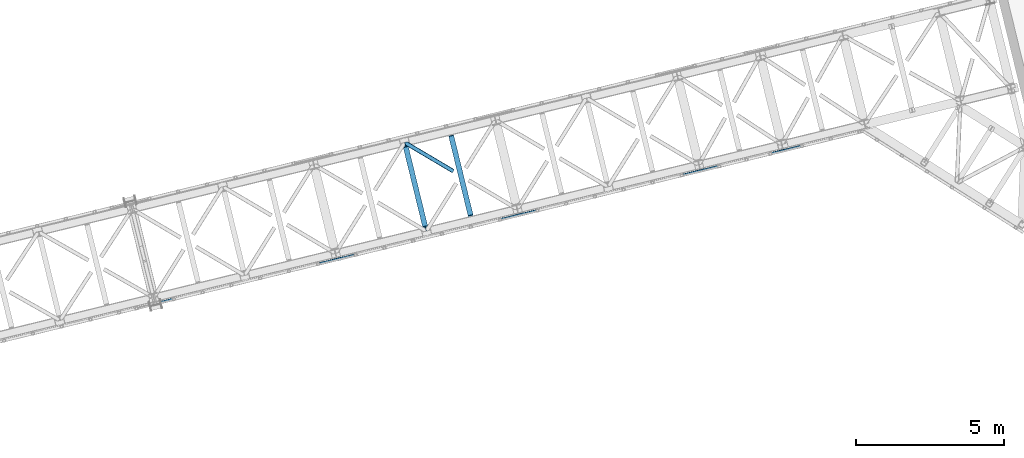
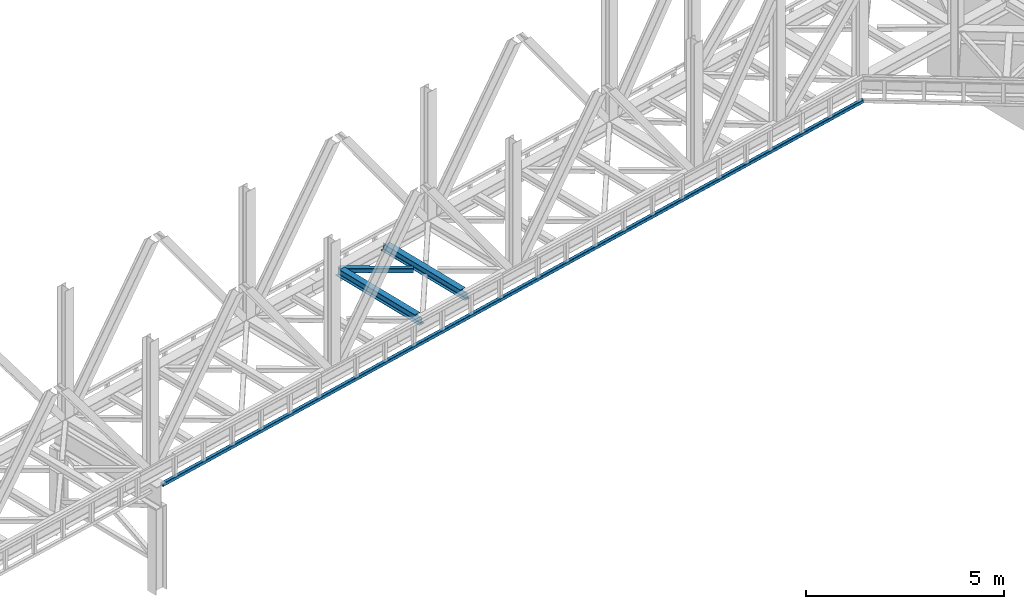
# One storey, part 65 of 93: 3 beams, 1 member.
"""IFC4 building model written with IfcOpenShell, lengths in millimetres."""

from ifc_helpers import new_model, entity, si_unit, converted_unit, derived_unit, direction, frame, origin, place, context, subcontext, project, spatial, triangles, polygons, material, type_object, element, save


model = new_model("IFC4")

# Units and contexts
model_context = context("Model", 3, precision=0.01, world=origin(), true_north=direction((6.12303176911189e-17, 1.0)))
plan_context = context("Plan", 3, precision=0.01, world=origin(), true_north=direction((6.12303176911189e-17, 1.0)))
body_context = subcontext(model_context, "Body", "Model", "MODEL_VIEW")
ifc_project = project(units=[si_unit("LENGTHUNIT", "METRE", prefix="MILLI"), si_unit("AREAUNIT", "SQUARE_METRE"), si_unit("VOLUMEUNIT", "CUBIC_METRE"), converted_unit("PLANEANGLEUNIT", "DEGREE", entity("IfcRatioMeasure", 0.0174532925199433), si_unit("PLANEANGLEUNIT", "RADIAN"), dimensions=[0, 0, 0, 0, 0, 0, 0]), si_unit("MASSUNIT", "GRAM", prefix="KILO"), derived_unit("MASSDENSITYUNIT", [(si_unit("MASSUNIT", "GRAM", prefix="KILO"), 1), (si_unit("LENGTHUNIT", "METRE"), -3)]), derived_unit("MOMENTOFINERTIAUNIT", [(si_unit("LENGTHUNIT", "METRE"), 4)]), si_unit("TIMEUNIT", "SECOND"), si_unit("FREQUENCYUNIT", "HERTZ"), si_unit("THERMODYNAMICTEMPERATUREUNIT", "DEGREE_CELSIUS"), derived_unit("THERMALTRANSMITTANCEUNIT", [(si_unit("MASSUNIT", "GRAM", prefix="KILO"), 1), (si_unit("THERMODYNAMICTEMPERATUREUNIT", "KELVIN"), -1), (si_unit("TIMEUNIT", "SECOND"), -3)]), derived_unit("VOLUMETRICFLOWRATEUNIT", [(si_unit("LENGTHUNIT", "METRE"), 3), (si_unit("TIMEUNIT", "SECOND"), -1)]), derived_unit("MASSFLOWRATEUNIT", [(si_unit("MASSUNIT", "GRAM", prefix="KILO"), 1), (si_unit("TIMEUNIT", "SECOND"), -1)]), derived_unit("ROTATIONALFREQUENCYUNIT", [(si_unit("TIMEUNIT", "SECOND"), -1)]), si_unit("ELECTRICCURRENTUNIT", "AMPERE"), si_unit("ELECTRICVOLTAGEUNIT", "VOLT"), si_unit("POWERUNIT", "WATT"), si_unit("FORCEUNIT", "NEWTON", prefix="KILO"), si_unit("ILLUMINANCEUNIT", "LUX"), si_unit("LUMINOUSFLUXUNIT", "LUMEN"), si_unit("LUMINOUSINTENSITYUNIT", "CANDELA"), derived_unit("USERDEFINED", [(si_unit("MASSUNIT", "GRAM", prefix="KILO"), -1), (si_unit("LENGTHUNIT", "METRE"), -2), (si_unit("TIMEUNIT", "SECOND"), 3), (si_unit("LUMINOUSFLUXUNIT", "LUMEN"), 1)]), derived_unit("LINEARVELOCITYUNIT", [(si_unit("LENGTHUNIT", "METRE"), 1), (si_unit("TIMEUNIT", "SECOND"), -1)]), si_unit("PRESSUREUNIT", "PASCAL"), derived_unit("USERDEFINED", [(si_unit("LENGTHUNIT", "METRE"), -2), (si_unit("MASSUNIT", "GRAM", prefix="KILO"), 1), (si_unit("TIMEUNIT", "SECOND"), -2)]), derived_unit("LINEARFORCEUNIT", [(si_unit("MASSUNIT", "GRAM", prefix="KILO"), 1), (si_unit("LENGTHUNIT", "METRE"), 1), (si_unit("TIMEUNIT", "SECOND"), -2), (si_unit("LENGTHUNIT", "METRE"), -1)]), derived_unit("PLANARFORCEUNIT", [(si_unit("MASSUNIT", "GRAM", prefix="KILO"), 1), (si_unit("LENGTHUNIT", "METRE"), 1), (si_unit("TIMEUNIT", "SECOND"), -2), (si_unit("LENGTHUNIT", "METRE"), -2)])], contexts=[model_context, plan_context])

# Site, building, storey
site_placement = place(None, origin())
site = spatial("IfcSite", under=ifc_project, at=site_placement, CompositionType="ELEMENT")
building_placement = place(site_placement, origin())
building = spatial("IfcBuilding", under=site, at=building_placement, CompositionType="ELEMENT")
storey_placement = place(building_placement, frame((0.0, 0.0, 15900.0)))
storey = spatial("IfcBuildingStorey", under=building, at=storey_placement, CompositionType="ELEMENT", Elevation=15900.0)

# Beams
ifc_material = material(Name="Metal painted (White)")
beam_type_1 = type_object("IfcBeamType", PredefinedType="BEAM")
beam_1_placement = place(storey_placement, frame((-21033.994134998, 12667.6706069707, 3441.0)))
element("IfcBeam", 1, at=beam_1_placement, inside=storey, type_object=beam_type_1, material=ifc_material, ObjectType="Steel Beam", PredefinedType="BEAM", context=body_context, shape_type="Tessellation", body=[
    polygons([(896.722476515612, 41.4445662733146, 11.000000000004), (896.722476515612, 41.4445662733146, 2.16573425859679e-12), (170.021610174765, 3022.65205668043, 2.16573425859679e-12), (170.021610174765, 3022.65205668043, 11.000000000004), (830.65693656199, 25.3403919499699, 11.000000000004), (103.956070221139, 3006.54788235708, 11.000000000004), (824.708186540694, 23.8903211957439, 12.2179274798217), (98.007320199847, 3005.09781160286, 12.2179274798217), (819.665079784585, 22.6610105689237, 15.6862915010257), (92.964213443734, 3003.86850097604, 15.6862915010257), (816.295383581409, 21.8396114687162, 20.8770650821657), (89.5945172405581, 3003.04710187583, 20.8770650821657), (815.112103631732, 21.5511744621271, 27.0000000000047), (88.4112372908809, 3002.75866486924, 27.0000000000047), (81.6103728838844, 3001.1008822183, 27.0000000000047), (81.6103728838888, 3001.1008822183, 203.000000000006), (88.4112372908939, 3002.75866486924, 203.000000000006), (0.0, 2981.20749040711, 2.16573425859679e-12), (4.33146851719357e-12, 2981.20749040712, 10.9999999999997), (66.0655399536302, 2997.31166473046, 11.000000000004), (72.0142899749184, 2998.76173548469, 12.2179274798195), (77.0573967310313, 2999.99104611151, 15.6862915010192), (80.4270929342072, 3000.81244521171, 20.8770650821657), (815.11210363174, 21.5511744621271, 203.000000000006), (808.311239224731, 19.8933918111941, 203.000000000006), (808.311239224731, 19.8933918111919, 27.0000000000047), (807.127959275054, 19.6049548046028, 20.8770650821657), (803.758263071878, 18.7835557043952, 15.6862915010192), (798.715156315769, 17.5542450775729, 12.2179274798195), (792.766406294477, 16.1041743233468, 11.000000000004), (726.700866340851, 2.16573425859679e-12, 10.9999999999997), (726.700866340847, 2.16573425859679e-12, 2.16573425859679e-12), (775.945201911975, 182.229070489536, 203.069792164282), (124.290390378924, 2855.56852806081, 203.000000000006), (124.513271168078, 2854.65418562638, 203.617301946336), (124.526185412598, 2854.60120565349, 217.000003693143), (775.799998669244, 182.824605273263, 217.000003676718), (775.800869277142, 182.821033832383, 204.00000679514), (769.234900758903, 180.199471824636, 203.006342981088), (769.012053092176, 181.113823838963, 203.617301946336), (768.999138847657, 181.166803811856, 217.000003693143), (117.725325591011, 2852.94340419209, 217.000003676718), (117.724454983117, 2852.94697563296, 204.00000679514), (117.580155394058, 2853.53894853354, 203.076120467494), (117.489525971923, 2853.91074540987, 203.000000000006), (776.983483393267, 183.112202246701, 223.122939328039), (780.352479801942, 183.936472070578, 228.313710402595), (785.395115205966, 185.167716295886, 231.782072735464), (791.343694076674, 186.618489150568, 232.999999602236), (857.409144942201, 202.723028934504, 232.999999283132), (857.407671605764, 202.729072911377, 243.999994005812), (687.386290701834, 161.283566114484, 243.999994827032), (687.387764038276, 161.277522137611, 233.000000104353), (753.453214903804, 177.382061921547, 232.999999785253), (759.402120032129, 178.83149638977, 231.782072861016), (764.445684539269, 180.058929212905, 228.313710479427), (767.816071449005, 180.877494870334, 223.12293937232), (116.541840866984, 2852.65580721864, 223.122939328039), (113.172844458304, 2851.83153739476, 228.313710402595), (108.130209054276, 2850.60029316945, 231.782072735464), (102.181630183577, 2849.14952031477, 232.999999602236), (36.1161793180448, 2833.04498053084, 232.999999283128), (36.1176526544823, 2833.03893655396, 243.999994005812), (206.139033558408, 2874.48444335086, 243.999994827032), (206.13756022197, 2874.49048732773, 233.000000104357), (140.072109356447, 2858.38594754379, 232.999999785253), (134.123204228112, 2856.93651307557, 231.782072861012), (129.079639720982, 2855.70908025244, 228.313710479427), (125.709252811241, 2854.89051459501, 223.12293937232)], [[[1, 2, 3, 4]], [[5, 1, 4, 6]], [[7, 5, 6, 8]], [[9, 7, 8, 10]], [[11, 9, 10, 12]], [[13, 11, 12, 14]], [[15, 16, 17, 14, 12, 10, 8, 6, 4, 3, 18, 19, 20, 21, 22, 23]], [[13, 24, 25, 26, 27, 28, 29, 30, 31, 32, 2, 1, 5, 7, 9, 11]], [[2, 32, 18, 3]], [[32, 31, 19, 18]], [[31, 30, 20, 19]], [[27, 26, 15, 23]], [[28, 27, 23, 22]], [[29, 28, 22, 21]], [[30, 29, 21, 20]], [[33, 24, 13, 14, 17, 34, 35, 36, 37, 38]], [[25, 39, 40, 41, 42, 43, 44, 16, 15, 26]], [[39, 25, 24, 33]], [[45, 34, 17, 16]], [[41, 40, 38, 37, 46, 47, 48, 49, 50, 51, 52, 53, 54, 55, 56, 57]], [[42, 58, 59, 60, 61, 62, 63, 64, 65, 66, 67, 68, 69, 36, 35, 43]], [[46, 37, 36, 69]], [[47, 46, 69, 68]], [[48, 47, 68, 67]], [[49, 48, 67, 66]], [[50, 49, 66, 65]], [[51, 50, 65, 64]], [[52, 51, 64, 63]], [[53, 52, 63, 62]], [[54, 53, 62, 61]], [[55, 54, 61, 60]], [[56, 55, 60, 59]], [[57, 56, 59, 58]], [[41, 57, 58, 42]]], closed=False),
])
beam_2_placement = place(storey_placement, frame((-19498.9418831345, 13041.8558338955, 3441.0)))
element("IfcBeam", 2, at=beam_2_placement, inside=storey, type_object=beam_type_1, material=ifc_material, ObjectType="Steel Beam", PredefinedType="BEAM", context=body_context, shape_type="Tessellation", body=[
    polygons([(896.722476515612, 41.4445662733125, 11.000000000004), (896.722476515612, 41.4445662733125, 2.16573425859679e-12), (170.021610174761, 3022.65205668042, 2.16573425859679e-12), (170.021610174763, 3022.65205668042, 11.000000000004), (830.656936561993, 25.3403919499656, 11.000000000004), (103.956070221144, 3006.54788235708, 11.000000000004), (824.708186540689, 23.8903211957374, 12.217927479826), (98.0073201998383, 3005.09781160285, 12.217927479826), (819.665079784589, 22.6610105689237, 15.6862915010192), (92.9642134437362, 3003.86850097603, 15.6862915010192), (816.295383581413, 21.8396114687119, 20.8770650821657), (89.5945172405603, 3003.04710187582, 20.8770650821657), (815.11210363173, 21.5511744621227, 27.0000000000047), (88.4112372908809, 3002.75866486924, 27.0000000000047), (81.6103728838822, 3001.1008822183, 27.0000000000047), (81.6103728838801, 3001.1008822183, 203.000000000006), (88.4112372908809, 3002.75866486924, 203.000000000006), (0.0, 2981.20749040711, 2.16573425859679e-12), (2.16573425859679e-12, 2981.20749040711, 10.9999999999997), (66.0655399536216, 2997.31166473045, 11.000000000004), (72.0142899749205, 2998.76173548469, 12.2179274798217), (77.0573967310183, 2999.9910461115, 15.686291501017), (80.4270929342029, 3000.81244521171, 20.8770650821657), (815.112103631732, 21.5511744621249, 203.000000000006), (808.311239224731, 19.8933918111897, 203.000000000006), (808.311239224731, 19.8933918111897, 27.0000000000047), (807.127959275052, 19.6049548045984, 20.8770650821657), (803.758263071869, 18.7835557043909, 15.686291501017), (798.715156315769, 17.5542450775729, 12.2179274798217), (792.766406294472, 16.1041743233447, 11.000000000004), (726.700866340851, 2.16573425859679e-12, 10.9999999999997), (726.700866340851, 2.16573425859679e-12, 2.16573425859679e-12), (775.945201911964, 182.229070489534, 203.069792164282), (124.290390378922, 2855.5685280608, 203.000000000006), (124.513271168068, 2854.65418562638, 203.617301946336), (124.526185412589, 2854.60120565348, 217.000003693143), (775.79999866924, 182.824605273258, 217.000003676718), (775.800869277134, 182.821033832379, 204.00000679514), (769.234900758899, 180.199471824632, 203.006342981088), (769.012053092174, 181.113823838958, 203.617301946336), (768.999138847649, 181.166803811849, 217.000003693143), (117.725325591002, 2852.94340419208, 217.000003676718), (117.724454983108, 2852.94697563296, 204.00000679514), (117.580155394052, 2853.53894853353, 203.076120467494), (117.489525971919, 2853.91074540987, 203.000000000006), (776.983483393269, 183.112202246699, 223.122939328039), (780.352479801942, 183.93647207058, 228.313710402595), (785.395115205957, 185.167716295882, 231.78207273546), (791.343694076674, 186.618489150565, 232.999999602236), (857.40914494219, 202.723028934499, 232.999999283132), (857.407671605755, 202.729072911373, 243.999994005812), (687.38629070184, 161.283566114482, 243.999994827032), (687.38776403828, 161.277522137609, 233.000000104353), (753.453214903799, 177.382061921543, 232.999999785253), (759.402120032134, 178.831496389768, 231.782072861012), (764.445684539254, 180.058929212901, 228.313710479431), (767.816071449001, 180.877494870332, 223.12293937232), (116.541840866979, 2852.65580721863, 223.122939328039), (113.172844458293, 2851.83153739476, 228.313710402599), (108.130209054278, 2850.60029316945, 231.782072735464), (102.181630183568, 2849.14952031477, 232.999999602236), (36.1161793180448, 2833.04498053084, 232.999999283128), (36.1176526544823, 2833.03893655396, 243.999994005812), (206.139033558399, 2874.48444335085, 243.999994827032), (206.137560221957, 2874.49048732772, 233.000000104357), (140.072109356447, 2858.38594754379, 232.999999785253), (134.123204228102, 2856.93651307557, 231.782072861007), (129.079639720982, 2855.70908025243, 228.313710479427), (125.709252811245, 2854.89051459501, 223.12293937232)], [[[1, 2, 3, 4]], [[5, 1, 4, 6]], [[7, 5, 6, 8]], [[9, 7, 8, 10]], [[11, 9, 10, 12]], [[13, 11, 12, 14]], [[15, 16, 17, 14, 12, 10, 8, 6, 4, 3, 18, 19, 20, 21, 22, 23]], [[13, 24, 25, 26, 27, 28, 29, 30, 31, 32, 2, 1, 5, 7, 9, 11]], [[2, 32, 18, 3]], [[32, 31, 19, 18]], [[31, 30, 20, 19]], [[27, 26, 15, 23]], [[28, 27, 23, 22]], [[29, 28, 22, 21]], [[30, 29, 21, 20]], [[33, 24, 13, 14, 17, 34, 35, 36, 37, 38]], [[25, 39, 40, 41, 42, 43, 44, 16, 15, 26]], [[39, 25, 24, 33]], [[45, 34, 17, 16]], [[41, 40, 38, 37, 46, 47, 48, 49, 50, 51, 52, 53, 54, 55, 56, 57]], [[42, 58, 59, 60, 61, 62, 63, 64, 65, 66, 67, 68, 69, 36, 35, 43]], [[46, 37, 36, 69]], [[47, 46, 69, 68]], [[48, 47, 68, 67]], [[49, 48, 67, 66]], [[50, 49, 66, 65]], [[51, 50, 65, 64]], [[52, 51, 64, 63]], [[53, 52, 63, 62]], [[54, 53, 62, 61]], [[55, 54, 61, 60]], [[56, 55, 60, 59]], [[57, 56, 59, 58]], [[41, 57, 58, 42]]], closed=False),
])

# Member
member_type = type_object("IfcMemberType", PredefinedType="BRACE")
member_placement = place(storey_placement, frame((-20945.2866394043, 14645.7781311035, 3510.00011901855)))
element("IfcMember", 3, at=member_placement, inside=storey, type_object=member_type, ObjectType="Steel Horizontal Brace", PredefinedType="BRACE", context=body_context, shape_type="Tessellation", body=[
    triangles([(1672.21653442383, 120.471716308593, 122.500662231447), (1672.21653442383, 120.471716308593, 17.5000946044929), (91.5013916015632, 1056.29133911133, 122.500662231447), (91.5013916015632, 1056.29133911133, 17.5000946044929), (1663.30196228027, 105.413333129884, 139.999594116212), (1666.71221923828, 111.175772094726, 138.667117309571), (76.4813781738267, 1052.62993469238, 138.667117309571), (67.167993164061, 1050.36030578613, 139.999594116212), (1669.60506591797, 116.060357666016, 134.874325561526), (84.376245117186, 1054.55423583984, 134.874325561526), (1671.53750610352, 119.325274658204, 129.197927856447), (89.6480163574233, 1055.84020385742, 129.197927856447), (18.7686218261733, 956.992749023439, 139.999594116212), (1609.80987854004, 15.0595458984371, 139.999594116212), (0.0, 1033.98688659668, 139.999594116212), (1600.89065551758, 0.0, 122.500662231447), (1601.57317199707, 1.14760437011682, 129.197927856447), (24.5612915039055, 933.226757812501, 122.500662231447), (24.1217834472664, 935.035949707031, 129.197927856447), (1603.50677490234, 4.41135864257922, 134.874325561526), (22.8660461425789, 940.18796081543, 134.874325561526), (1606.39962158203, 9.29710693359448, 138.667117309571), (20.9847656249985, 947.897955322265, 138.667117309571), (1600.89065551758, 0.0, 17.5000946044929), (24.5612915039055, 933.226757812501, 17.5000946044929), (1671.53750610352, 119.325274658204, 10.8028289794929), (89.5619750976548, 1055.81927490234, 10.8167816162131), (162.736578369142, 1012.4207611084, 10.5005218505867), (1669.60506591797, 116.060357666016, 5.12526855468968), (165.152709960938, 1006.73157348633, 5.12526855468968), (164.09696044922, 1011.0638671875, 9.50058288574292), (163.769073486328, 1011.39059143067, 9.74126586914281), (163.420257568359, 1011.74289550781, 10.0005523681648), (163.066790771485, 1012.09287414551, 10.2586761474631), (89.473608398439, 1055.79718322754, 10.5005218505867), (1666.71221923828, 111.175772094726, 1.33247680664135), (167.033990478514, 999.020416259766, 1.33247680664135), (1663.30196228027, 105.413333129884, 0.0), (169.250134277343, 989.925622558594, 0.0), (1609.80987854004, 15.0595458984371, 0.0), (204.010803222656, 847.325024414064, 0.0), (166.88748779297, 995.391567993165, 10.5005218505867), (72.0351379394524, 1051.54627990723, 10.5005218505867), (168.582733154297, 992.660339355469, 9.50058288574292), (168.166479492189, 993.33355407715, 9.74591674804833), (167.738598632812, 994.02653503418, 10.0005523681648), (167.306066894533, 994.718353271484, 10.2540252685576), (1666.03784179688, 110.037469482422, 12.1260040283232), (1667.97028198242, 113.301223754883, 17.8035644531265), (79.9160522460952, 1053.46709289551, 17.8035644531265), (1663.14499511719, 105.151721191407, 8.3320495605476), (169.398962402345, 989.317520141602, 8.81690368652562), (74.1140808105483, 1052.05322570801, 12.4271484375022), (171.566271972657, 980.419226074218, 6.99957275390625), (1659.73357543945, 99.3892822265625, 6.99957275390625), (1668.64814758301, 114.447665405274, 24.4996673583992), (81.7694274902351, 1053.91822814941, 24.4996673583992), (1668.64814758301, 114.447665405274, 115.501089477541), (81.7694274902351, 1053.91822814941, 115.501089477541), (74.641955566407, 1052.18228759766, 127.87475280762), (66.7494140624985, 1050.25798645019, 131.667544555665), (79.9160522460952, 1053.46709289551, 122.196029663086), (57.4360290527329, 1047.98719482422, 133.000021362306), (0.0, 1033.98688659668, 133.000021362306), (1667.97028198242, 113.301223754883, 122.196029663086), (1666.03784179688, 110.037469482422, 127.87475280762), (1663.14499511719, 105.151721191407, 131.667544555665), (1659.73357543945, 99.3892822265625, 133.000021362306), (16.4501586914048, 966.50030822754, 133.000021362306), (1613.37361450195, 21.0824340820309, 133.000021362306), (1613.37361450195, 21.0824340820309, 6.99957275390625), (201.692340087891, 856.832583618165, 6.99957275390625), (1607.06934814453, 10.434246826173, 127.87475280762), (1609.96219482422, 15.3199951171882, 131.667544555665), (1604.4590423584, 6.02405090332104, 115.501089477541), (1605.13690795899, 7.17049255371057, 122.196029663086), (1606.39962158203, 9.29710693359448, 1.33247680664135), (1607.06934814453, 10.434246826173, 12.1260040283232), (1603.50677490234, 4.41135864257922, 5.12526855468968), (1609.96219482422, 15.3199951171882, 8.3320495605476), (1601.57317199707, 1.14760437011682, 10.8028289794929), (1604.4590423584, 6.02405090332104, 24.4996673583992), (1605.13690795899, 7.17049255371057, 17.8035644531265), (18.6686279296882, 957.404351806641, 131.667544555665), (20.547583007814, 949.694357299804, 127.87475280762), (21.8033203125015, 944.542346191407, 122.196029663086), (22.2451538085952, 942.733154296875, 115.501089477541), (22.2451538085952, 942.733154296875, 24.4996673583992), (21.7823913574211, 944.627224731446, 17.8163543701194), (21.7614624023445, 944.717916870117, 17.5000946044929), (203.861975097658, 847.933126831054, 8.81690368652562), (206.226947021485, 838.23023071289, 1.33247680664135), (204.678204345702, 844.590307617187, 9.50058288574292), (208.105902099611, 830.520236206055, 5.12526855468968), (209.163977050783, 826.187942504883, 9.50058288574292), (204.682855224608, 843.327593994141, 10.2075164794951), (204.324737548828, 843.305502319336, 10.3540191650391), (203.966619873048, 843.284573364259, 10.5005218505867), (27.0146301269524, 945.867846679688, 12.1260040283232), (28.3471069335938, 947.254971313478, 10.5005218505867), (204.682855224608, 843.958950805665, 9.85404968261719), (32.1398986816421, 930.362979125977, 10.8179443359404), (209.136071777342, 825.983303833009, 9.88311767578125), (208.117529296876, 826.255380249024, 10.5005218505867), (208.803533935548, 826.071670532227, 10.0842681884787), (32.4980163574219, 930.225778198243, 10.5005218505867)], [[1, 2, 3], [4, 3, 2], [5, 6, 7], [7, 8, 5], [6, 9, 10], [10, 7, 6], [9, 11, 12], [12, 10, 9], [11, 1, 3], [3, 12, 11], [5, 13, 14], [13, 5, 8], [15, 13, 8], [16, 17, 18], [19, 18, 17], [17, 20, 19], [21, 19, 20], [20, 22, 21], [23, 21, 22], [22, 14, 23], [13, 23, 14], [24, 16, 18], [18, 25, 24], [26, 27, 4], [27, 26, 28], [26, 29, 30], [30, 31, 26], [26, 32, 33], [32, 26, 31], [26, 34, 28], [34, 26, 33], [28, 35, 27], [29, 36, 37], [37, 30, 29], [36, 38, 39], [39, 37, 36], [4, 2, 26], [38, 40, 41], [41, 39, 38], [28, 42, 35], [43, 35, 42], [31, 44, 45], [45, 32, 31], [32, 45, 46], [46, 33, 32], [33, 46, 47], [47, 34, 33], [34, 47, 42], [42, 28, 34], [48, 49, 50], [45, 51, 46], [45, 44, 51], [42, 47, 51], [47, 46, 51], [44, 52, 51], [48, 53, 42], [42, 51, 48], [53, 43, 42], [51, 52, 54], [54, 55, 51], [50, 53, 48], [49, 56, 57], [57, 50, 49], [56, 58, 59], [59, 57, 56], [60, 61, 7], [10, 60, 7], [10, 12, 62], [60, 10, 62], [62, 12, 3], [61, 8, 7], [15, 63, 64], [15, 8, 63], [61, 63, 8], [62, 3, 59], [57, 4, 50], [3, 57, 59], [4, 27, 50], [3, 4, 57], [35, 50, 27], [35, 53, 50], [35, 43, 53], [58, 65, 59], [62, 59, 65], [65, 66, 62], [60, 62, 66], [66, 67, 60], [61, 60, 67], [67, 68, 61], [63, 61, 68], [68, 69, 63], [68, 70, 69], [69, 64, 63], [71, 55, 72], [54, 72, 55], [11, 66, 65], [58, 2, 1], [11, 65, 1], [11, 9, 66], [65, 58, 1], [66, 9, 6], [68, 5, 14], [5, 67, 6], [67, 5, 68], [67, 66, 6], [26, 48, 29], [56, 2, 58], [2, 49, 26], [49, 2, 56], [26, 49, 48], [38, 55, 40], [36, 29, 48], [48, 51, 36], [51, 55, 38], [38, 36, 51], [73, 22, 20], [14, 70, 68], [14, 74, 70], [74, 14, 22], [73, 74, 22], [75, 16, 24], [17, 76, 73], [20, 17, 73], [76, 17, 16], [75, 76, 16], [77, 78, 79], [40, 55, 71], [71, 80, 40], [80, 78, 77], [77, 40, 80], [81, 79, 78], [24, 82, 75], [83, 24, 81], [24, 83, 82], [83, 81, 78], [70, 74, 84], [84, 69, 70], [74, 73, 85], [85, 84, 74], [73, 76, 86], [86, 85, 73], [76, 75, 87], [87, 86, 76], [75, 82, 87], [88, 87, 82], [86, 87, 18], [18, 19, 86], [21, 86, 19], [86, 21, 85], [18, 88, 25], [89, 90, 25], [25, 88, 89], [87, 88, 18], [84, 23, 13], [15, 69, 13], [64, 69, 15], [84, 85, 23], [23, 85, 21], [69, 84, 13], [44, 30, 37], [39, 44, 37], [54, 52, 39], [54, 39, 72], [30, 44, 31], [39, 52, 44], [72, 41, 91], [41, 92, 93], [41, 72, 39], [94, 93, 92], [41, 93, 91], [94, 95, 93], [83, 89, 88], [71, 72, 91], [78, 96, 97], [97, 98, 78], [98, 99, 78], [98, 100, 99], [80, 91, 93], [93, 78, 80], [78, 93, 101], [101, 96, 78], [83, 78, 99], [99, 90, 83], [90, 89, 83], [91, 80, 71], [88, 82, 83], [24, 25, 102], [79, 103, 95], [81, 102, 104], [104, 79, 81], [104, 105, 79], [95, 94, 79], [40, 77, 92], [92, 41, 40], [77, 79, 94], [94, 92, 77], [106, 81, 24], [99, 106, 25], [99, 100, 106], [25, 90, 99], [98, 104, 106], [106, 100, 98]]),
])

# Beam
beam_type_2 = type_object("IfcBeamType", PredefinedType="BEAM")
beam_3_placement = place(storey_placement, frame((-29196.8992492676, 10223.7131652832, 3068.00035400391)))
element("IfcBeam", 4, at=beam_3_placement, inside=storey, type_object=beam_type_2, ObjectType="Steel Beam", PredefinedType="BEAM", context=body_context, shape_type="Tessellation", body=[
    triangles([(23740.1770889282, 5873.7821685791, 0.0), (23726.1331787109, 5788.01531066895, 0.0), (2.36729736328198, 87.4400115966801, 0.0), (21.3149780273452, 9.71568603515698, 0.0), (0.0, 97.1545349121097, 9.9993896484375), (23741.9339584351, 5884.50244445801, 9.9993896484375), (23741.6758346558, 5882.93277282715, 6.4647216796875), (0.181384277344478, 96.4150451660153, 6.17287902831958), (23741.4211990356, 5881.36310119629, 2.92889099121021), (0.692980957031978, 94.3093597412117, 2.92889099121021), (23740.7991439819, 5877.5726348877, 1.46386413574146), (1.46270141601417, 91.1572265625, 0.760418701171147), (0.0, 97.1545349121097, 90.0003204345703), (23741.9339584351, 5884.50244445801, 90.0003204345703), (1.46270141601417, 91.1572265625, 99.2381286621094), (2.36729736328198, 87.4400115966801, 99.9997100830078), (23740.1770889282, 5873.7821685791, 99.9997100830078), (0.692980957031978, 94.3093597412117, 97.0708190917976), (23740.7991439819, 5877.5726348877, 98.5358459472664), (0.181384277344478, 96.4150451660153, 93.8268310546882), (23741.4211990356, 5881.36310119629, 97.0708190917976), (23741.6758346558, 5882.93277282715, 93.5349884033203), (23726.1331787109, 5788.01531066895, 99.9997100830078), (21.3149780273452, 9.71568603515698, 99.9997100830078), (23.5032165527336, 0.739489746094478, 93.8268310546882), (23.6822753906235, 0.0, 90.0003204345703), (23724.3757278442, 5777.29503479004, 90.0003204345703), (22.9892944335952, 2.84517517089807, 97.0708190917976), (23724.6344329834, 5778.8647064209, 93.5349884033203), (22.2195739746094, 5.99730834960974, 99.2381286621094), (23724.8931381226, 5780.43554077148, 97.0708190917976), (23725.5111236572, 5784.22484436035, 98.5358459472664), (23.6822753906235, 0.0, 9.9993896484375), (23724.3757278442, 5777.29503479004, 9.9993896484375), (23725.5111236572, 5784.22484436035, 1.46386413574146), (22.2195739746094, 5.99730834960974, 0.760418701171147), (23724.8931381226, 5780.43554077148, 2.92889099121021), (22.9892944335952, 2.84517517089807, 2.92889099121021), (23724.6344329834, 5778.8647064209, 6.4647216796875), (23.5032165527336, 0.739489746094478, 6.17287902831958), (1.87662963867115, 89.4515167236332, 7.92858581542896), (1.36503295898365, 91.5583648681641, 11.1725738525383), (1.18364868163917, 92.2978546142585, 15.0002471923835), (3.55327148437573, 82.5821685791016, 4.99969482421875), (2.64635009765698, 86.2993835449215, 5.76127624511719), (1.87662963867115, 89.4515167236332, 92.0711242675789), (1.18364868163917, 92.2978546142585, 84.9994628906243), (1.36503295898365, 91.5583648681641, 88.8271362304695), (3.55327148437573, 82.5821685791016, 95.0000152587891), (2.64635009765698, 86.2993835449215, 94.2384338378906), (21.8056457519524, 7.70301818847656, 7.92858581542896), (20.1313293457024, 14.5735290527355, 4.99969482421875), (21.0359252929702, 10.8551513671882, 5.76127624511719), (22.4986267089844, 4.85784301757849, 15.0002471923835), (22.3172424316399, 5.59733276367297, 11.1725738525383), (21.8056457519524, 7.70301818847656, 92.0711242675789), (20.1313293457024, 14.5735290527355, 95.0000152587891), (21.0359252929702, 10.8551513671882, 94.2384338378906), (22.4986267089844, 4.85784301757849, 84.9994628906243), (22.3172424316399, 5.59733276367297, 88.8271362304695), (23740.5404388428, 5876.00180053711, 7.92858581542896), (23739.923034668, 5872.21249694824, 6.4647216796875), (23740.5404388428, 5876.00180053711, 92.0711242675789), (23740.7991439819, 5877.5726348877, 88.5352935791016), (23741.0578491211, 5879.14230651856, 84.9994628906243), (23741.0578491211, 5879.14230651856, 15.0002471923835), (23739.3009796143, 5868.42203063965, 95.0000152587891), (23727.0092880249, 5793.3754486084, 95.0000152587891), (23739.923034668, 5872.21249694824, 93.5349884033203), (23740.7991439819, 5877.5726348877, 11.4644165039063), (23739.3009796143, 5868.42203063965, 4.99969482421875), (23725.7692474365, 5785.79567871094, 92.0711242675789), (23725.5111236572, 5784.22484436035, 88.5352935791016), (23726.3918838501, 5789.58614501953, 93.5349884033203), (23725.2564880371, 5782.65517272949, 84.9994628906243), (23725.7692474365, 5785.79567871094, 7.92858581542896), (23727.0092880249, 5793.3754486084, 4.99969482421875), (23726.3918838501, 5789.58614501953, 6.4647216796875), (23725.2564880371, 5782.65517272949, 15.0002471923835), (23725.5111236572, 5784.22484436035, 11.4644165039063)], [[1, 2, 3], [4, 3, 2], [5, 6, 7], [8, 7, 9], [10, 9, 11], [12, 11, 1], [1, 3, 12], [11, 12, 10], [9, 10, 8], [7, 8, 5], [6, 5, 13], [13, 14, 6], [15, 16, 17], [18, 15, 19], [20, 18, 21], [13, 20, 22], [22, 14, 13], [21, 22, 20], [19, 21, 18], [17, 19, 15], [23, 17, 16], [16, 24, 23], [25, 26, 27], [28, 25, 29], [30, 28, 31], [24, 30, 32], [32, 23, 24], [31, 32, 30], [29, 31, 28], [27, 29, 25], [33, 34, 27], [27, 26, 33], [4, 2, 35], [36, 35, 37], [38, 37, 39], [40, 39, 34], [34, 33, 40], [39, 40, 38], [37, 38, 36], [35, 36, 4], [8, 41, 42], [43, 13, 5], [8, 42, 5], [8, 10, 41], [42, 43, 5], [41, 10, 12], [44, 3, 4], [3, 45, 12], [45, 3, 44], [45, 41, 12], [20, 46, 18], [47, 13, 43], [13, 48, 20], [48, 13, 47], [20, 48, 46], [16, 49, 24], [15, 18, 46], [46, 50, 15], [50, 49, 16], [16, 15, 50], [51, 36, 38], [4, 52, 44], [4, 53, 52], [53, 4, 36], [51, 53, 36], [54, 33, 26], [40, 55, 51], [38, 40, 51], [55, 40, 33], [54, 55, 33], [30, 56, 28], [24, 49, 57], [57, 58, 24], [58, 56, 30], [30, 24, 58], [25, 28, 56], [26, 59, 54], [60, 26, 25], [26, 60, 59], [60, 25, 56], [9, 61, 62], [22, 63, 64], [65, 66, 14], [14, 22, 64], [21, 63, 22], [64, 65, 14], [63, 21, 19], [67, 17, 68], [17, 69, 19], [69, 17, 67], [69, 63, 19], [66, 6, 14], [70, 7, 6], [70, 6, 66], [11, 62, 1], [7, 70, 61], [9, 62, 11], [1, 71, 2], [71, 1, 62], [72, 29, 73], [23, 68, 17], [23, 32, 74], [23, 74, 68], [74, 32, 72], [73, 27, 75], [29, 72, 31], [31, 72, 32], [75, 27, 34], [29, 27, 73], [35, 76, 37], [2, 71, 77], [78, 2, 77], [35, 78, 76], [35, 2, 78], [39, 37, 76], [34, 79, 75], [80, 34, 39], [34, 80, 79], [80, 39, 76], [61, 9, 7], [77, 71, 44], [44, 52, 77], [45, 44, 71], [41, 45, 62], [42, 41, 61], [43, 42, 70], [70, 66, 43], [61, 70, 42], [62, 61, 41], [71, 62, 45], [43, 66, 65], [65, 47, 43], [47, 65, 64], [48, 64, 63], [46, 63, 69], [50, 69, 67], [67, 49, 50], [69, 50, 46], [63, 46, 48], [64, 48, 47], [67, 68, 49], [57, 49, 68], [57, 68, 74], [58, 74, 72], [56, 72, 73], [60, 73, 75], [75, 59, 60], [73, 60, 56], [72, 56, 58], [74, 58, 57], [79, 54, 75], [59, 75, 54], [55, 54, 79], [51, 55, 80], [53, 51, 76], [52, 53, 78], [78, 77, 52], [76, 78, 53], [80, 76, 51], [79, 80, 55]]),
])

save(model, "model.ifc")
